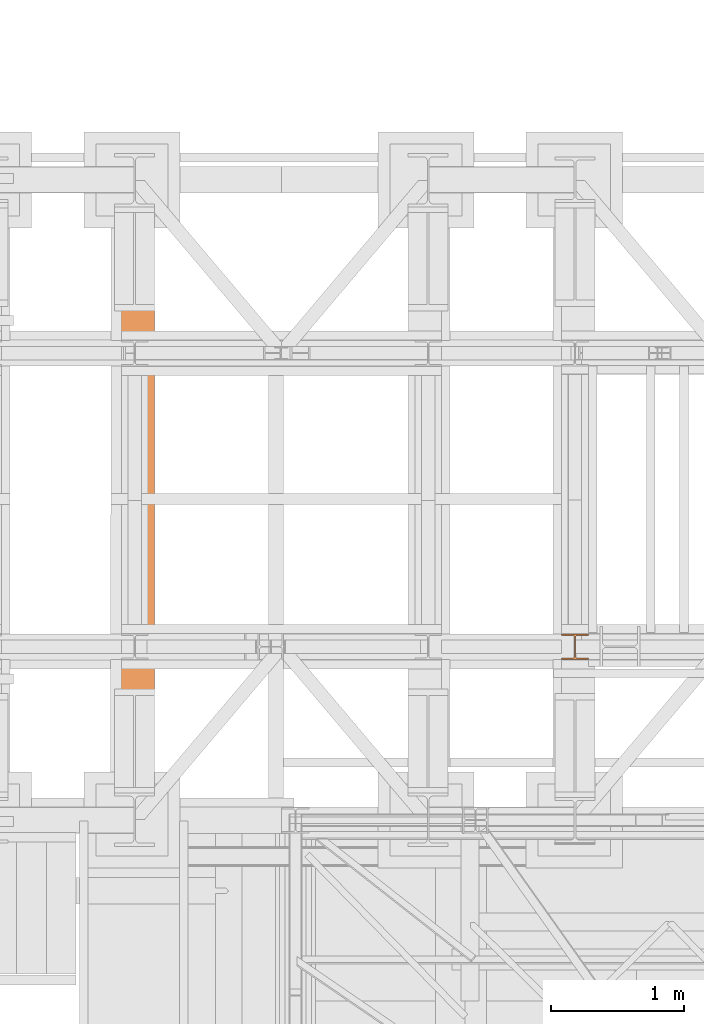
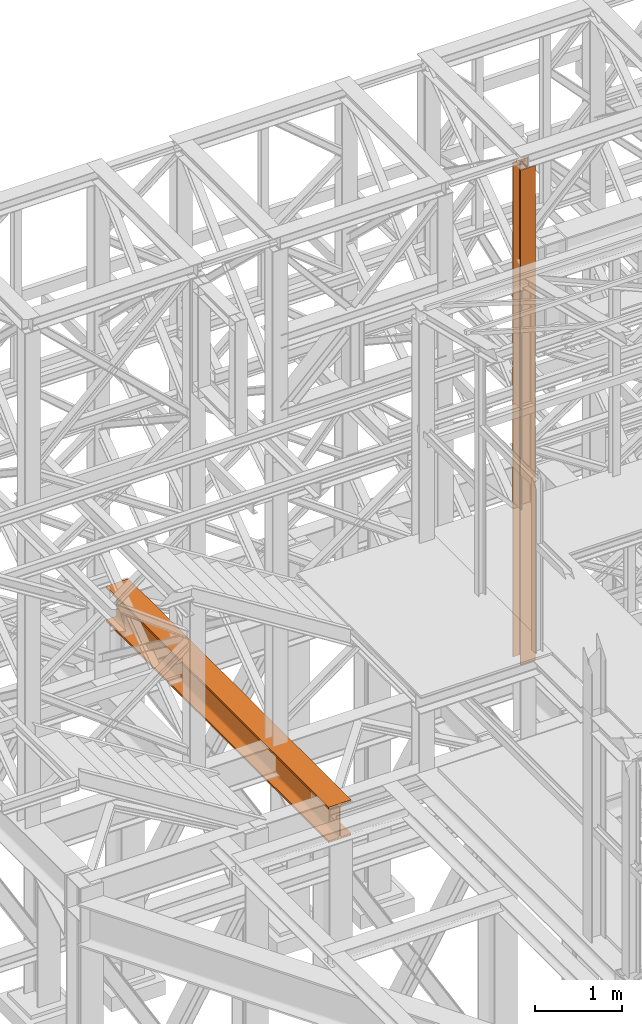
# One storey, part 114 of 208: 2 proxies.
"""IFC2X3 building model written with IfcOpenShell, lengths in millimetres."""

import ifcopenshell
import ifcopenshell.guid

model = None  # the IFC model being written
_history = None  # IfcOwnerHistory: only IFC2X3 demands one
_inside = {}  # id of a spatial element -> (the spatial element, [elements in it])
_under = {}  # id of a project, library or spatial element -> (it, [spatial elements below it])
_declared = {}  # id of a project -> (the project, [libraries it declares])
_typed = {}  # id of a type object -> (the type object, [elements of that type])
_made_of = {}  # id of a material, layer set ... -> (it, [elements and type objects made of it])


def new_model(schema):
    """Start an empty IFC model of exactly this schema.

    Asked for "IFC4X3", IfcOpenShell would pick the latest addendum, in which some entities
    have other attributes; the version numbers below select the first issue.
    IFC2X3 requires an IfcOwnerHistory on every rooted entity: one is made here for all.
    """
    global model, _history
    if schema == "IFC4X3":
        model = ifcopenshell.file(schema_version=(4, 3, 0, 0))
    else:
        model = ifcopenshell.file(schema=schema)
    _inside.clear()
    _under.clear()
    _declared.clear()
    _typed.clear()
    _made_of.clear()
    _history = None
    if model.schema == "IFC2X3":
        org = make("IfcOrganization", Name="unknown")
        user = make(
            "IfcPersonAndOrganization",
            ThePerson=make("IfcPerson", FamilyName="unknown"),
            TheOrganization=org,
        )
        app = make(
            "IfcApplication",
            ApplicationDeveloper=org,
            Version="unknown",
            ApplicationFullName="unknown",
            ApplicationIdentifier="unknown",
        )
        _history = make(
            "IfcOwnerHistory",
            OwningUser=user,
            OwningApplication=app,
            ChangeAction="ADDED",
            CreationDate=0,
        )
    return model


def make(cls, **values):
    """One entity of the class cls with the attributes given. An attribute that is None is left unset."""
    return model.create_entity(
        cls, **{name: value for name, value in values.items() if value is not None}
    )


def entity(cls, *values):
    """Any entity or typed value of the class cls, its attributes in the order of the schema. None: left unset."""
    e = model.create_entity(cls)
    for i, value in enumerate(values):
        if value is not None:
            e[i] = value
    return e


def rooted(cls, **values):
    """An entity with a GlobalId (a new one), such as an element, a storey or a relation."""
    return make(cls, GlobalId=ifcopenshell.guid.new(), OwnerHistory=_history, **values)


def si_unit(unit_type, name, prefix=None):
    """IfcSIUnit, for example si_unit("LENGTHUNIT", "METRE", prefix="MILLI")."""
    return make("IfcSIUnit", UnitType=unit_type, Prefix=prefix, Name=name)


def converted_unit(unit_type, name, factor, base, dimensions=None, offset=None):
    """IfcConversionBasedUnit, such as the inch: factor (a typed value) times the base unit."""
    return make(
        "IfcConversionBasedUnit"
        if offset is None
        else "IfcConversionBasedUnitWithOffset",
        ConversionOffset=offset,
        Dimensions=None
        if dimensions is None
        else entity("IfcDimensionalExponents", *dimensions),
        UnitType=unit_type,
        Name=name,
        ConversionFactor=make(
            "IfcMeasureWithUnit", ValueComponent=factor, UnitComponent=base
        ),
    )


def assignment(units):
    """IfcUnitAssignment: the units of a project."""
    return None if units is None else make("IfcUnitAssignment", Units=units)


def point(xyz):
    """IfcCartesianPoint."""
    return None if xyz is None else make("IfcCartesianPoint", Coordinates=xyz)


def direction(xyz):
    """IfcDirection."""
    return None if xyz is None else make("IfcDirection", DirectionRatios=xyz)


def frame(location, z_axis=None, x_axis=None):
    """IfcAxis2Placement3D, a coordinate frame: its origin and axes. An axis left out is left unset."""
    return make(
        "IfcAxis2Placement3D",
        Location=point(location),
        Axis=direction(z_axis),
        RefDirection=direction(x_axis),
    )


def origin():
    """The frame at (0, 0, 0) with its axes left unset."""
    return frame((0.0, 0.0, 0.0))


def origin_with_axes():
    """The frame at (0, 0, 0) with the z axis (0, 0, 1) and the x axis (1, 0, 0) written out."""
    return frame((0.0, 0.0, 0.0), z_axis=(0.0, 0.0, 1.0), x_axis=(1.0, 0.0, 0.0))


def place(relative_to, where):
    """IfcLocalPlacement: puts the frame where relative to a parent placement (None: the world)."""
    return make(
        "IfcLocalPlacement", PlacementRelTo=relative_to, RelativePlacement=where
    )


def context(
    kind, dimensions, precision=None, world=None, true_north=None, identifier=None
):
    """IfcGeometricRepresentationContext, for example the 3D "Model" context."""
    return make(
        "IfcGeometricRepresentationContext",
        ContextIdentifier=identifier,
        ContextType=kind,
        CoordinateSpaceDimension=dimensions,
        Precision=precision,
        WorldCoordinateSystem=world,
        TrueNorth=true_north,
    )


def subcontext(parent, identifier, kind, view, scale=None):
    """IfcGeometricRepresentationSubContext, for example "Body" below "Model"."""
    return make(
        "IfcGeometricRepresentationSubContext",
        ContextIdentifier=identifier,
        ContextType=kind,
        ParentContext=parent,
        TargetScale=scale,
        TargetView=view,
    )


def project(units=None, contexts=None):
    """IfcProject with its units and contexts."""
    return rooted(
        "IfcProject",
        Name="project",
        RepresentationContexts=contexts,
        UnitsInContext=assignment(units),
    )


def spatial(cls, under=None, at=None, **own):
    """A site, building, storey or space (cls), placed at a placement, below another one or the project."""
    s = rooted(cls, ObjectPlacement=at, **own)
    if under is not None:
        _under.setdefault(under.id(), (under, []))[1].append(s)
    return s


def faces_of(points, faces, orient=None, outer=None):
    """IfcFace entities. A face is a list of loops; a loop is a list of indices into points, from 0.

    orient and outer hold one flag for each loop. By default every Orientation is true, the
    first loop of a face is its IfcFaceOuterBound and the others are IfcFaceBound.
    """
    made = []
    for i, loops in enumerate(faces):
        bounds = []
        for j, loop in enumerate(loops):
            is_outer = j == 0 if outer is None else outer[i][j]
            bounds.append(
                make(
                    "IfcFaceOuterBound" if is_outer else "IfcFaceBound",
                    Bound=make("IfcPolyLoop", Polygon=[points[k] for k in loop]),
                    Orientation=True if orient is None else orient[i][j],
                )
            )
        made.append(make("IfcFace", Bounds=bounds))
    return made


def faceted_brep(points, faces, orient=None, outer=None, voids=None):
    """IfcFacetedBrep: a solid bounded by flat faces; with voids (closed shells), ...WithVoids."""
    shared = [point(p) for p in points]
    hull = make("IfcClosedShell", CfsFaces=faces_of(shared, faces, orient, outer))
    if voids is None:
        return make("IfcFacetedBrep", Outer=hull)
    return make(
        "IfcFacetedBrepWithVoids",
        Outer=hull,
        Voids=[
            make(cls, CfsFaces=faces_of(shared, fs, o, b)) for cls, fs, o, b in voids
        ],
    )


def shape(context_of_items, identifier, shape_type, items):
    """IfcShapeRepresentation: the items that make up one representation, for example the "Body"."""
    return make(
        "IfcShapeRepresentation",
        ContextOfItems=context_of_items,
        RepresentationIdentifier=identifier,
        RepresentationType=shape_type,
        Items=items,
    )


def made_of(thing, what):
    """Note that an element or type object is made of a material, layer set ...; save() writes the relation."""
    if what is not None:
        _made_of.setdefault(what.id(), (what, []))[1].append(thing)
    return thing


def element(
    cls,
    number,
    at=None,
    inside=None,
    cuts=None,
    type_object=None,
    material=None,
    context=None,
    identifier="Body",
    shape_type=None,
    held_by="IfcProductDefinitionShape",
    body=None,
    shapes=None,
    **own,
):
    """One element of the class cls, such as IfcWall. Its Tag is "e" and its number.

    at: its placement. inside: the storey or other place that contains it. cuts: it is an
    opening in that element (IfcRelVoidsElement). A single representation is given by context,
    identifier, shape_type and body (its items); several are given by shapes. held_by: the class
    of the entity that holds the representations. save() writes the other relations.
    """
    e = rooted(cls, Tag="e%d" % number, ObjectPlacement=at, **own)
    if body is not None:
        shapes = [shape(context, identifier, shape_type, body)]
    if shapes is not None:
        e.Representation = make(held_by, Representations=shapes)
    if inside is not None:
        _inside.setdefault(inside.id(), (inside, []))[1].append(e)
    if cuts is not None:
        rooted(
            "IfcRelVoidsElement", RelatingBuildingElement=cuts, RelatedOpeningElement=e
        )
    if type_object is not None:
        _typed.setdefault(type_object.id(), (type_object, []))[1].append(e)
    return made_of(e, material)


def aggregate(whole, parts):
    """IfcRelAggregates: a whole, such as a stair, and the parts it consists of."""
    return rooted("IfcRelAggregates", RelatingObject=whole, RelatedObjects=parts)


def save(model, path):
    """Write the relations noted so far, then the file.

    IfcRelAggregates (storeys below a building ...), IfcRelContainedInSpatialStructure (elements
    in a storey), IfcRelDefinesByType, IfcRelAssociatesMaterial and IfcRelDeclares: one each for
    every whole, place, type object, material and project.
    """
    for whole, parts in _under.values():
        aggregate(whole, parts)
    for where, things in _inside.values():
        rooted(
            "IfcRelContainedInSpatialStructure",
            RelatedElements=things,
            RelatingStructure=where,
        )
    for kind, things in _typed.values():
        rooted("IfcRelDefinesByType", RelatedObjects=things, RelatingType=kind)
    for what, things in _made_of.values():
        rooted("IfcRelAssociatesMaterial", RelatedObjects=things, RelatingMaterial=what)
    for by, libraries in _declared.values():
        rooted("IfcRelDeclares", RelatingContext=by, RelatedDefinitions=libraries)
    model.write(path)


model = new_model("IFC2X3")

# Units and contexts
model_context = context("Model", 3, precision=1e-05, world=origin())
plan_context = context("Plan", 3, precision=1e-05, world=origin())
body_context = subcontext(model_context, "Body", "Model", "MODEL_VIEW")
ifc_project = project(units=[si_unit("LENGTHUNIT", "METRE", prefix="MILLI"), converted_unit("PLANEANGLEUNIT", "DEGREE", entity("IfcPlaneAngleMeasure", 0.0174532925199433), si_unit("PLANEANGLEUNIT", "RADIAN"), dimensions=[0, 0, 0, 0, 0, 0, 0]), si_unit("AREAUNIT", "SQUARE_METRE"), si_unit("VOLUMEUNIT", "CUBIC_METRE")], contexts=[model_context, plan_context])

# Building, storey
building_placement = place(None, origin())
building = spatial("IfcBuilding", under=ifc_project, at=building_placement, CompositionType="COMPLEX")
storey_placement = place(building_placement, origin_with_axes())
storey = spatial("IfcBuildingStorey", under=building, at=storey_placement, Name="Geschoss", CompositionType="ELEMENT")

# Proxies
proxy_1_placement = place(storey_placement, frame((-156.745025510865, -17432.57439531566, 4784.990005364415), z_axis=(0.0, 0.0, 1.0), x_axis=(1.0, 0.0, 0.0)))
element("IfcBuildingElementProxy", 1, at=proxy_1_placement, inside=storey, context=body_context, shape_type="Brep", body=[
    faceted_brep([(300.01, 0.01000000000203727, 500.0100000000002), (300.0100000000006, 5140.010003576277, 500.0100000000002), (300.0100000000006, 5140.010003576277, 472.0100000000002), (300.01, 0.01000000000203727, 472.0100000000002), (300.01, 0.01000000000203727, 472.0100000000002), (300.0100000000006, 5140.010003576277, 472.0100000000002), (184.2600000000006, 5140.010003576277, 472.0100000000002), (184.26, 0.01000000000203727, 472.0100000000002), (184.26, 0.01000000000203727, 472.0100000000002), (184.2600000000006, 5140.010003576277, 472.0100000000002), (177.271909219226, 5140.010003576277, 471.0899181875066), (177.2719092192253, 0.01000000000203727, 471.0899181875066), (177.2719092192253, 0.01000000000203727, 471.0899181875066), (177.271909219226, 5140.010003576277, 471.0899181875066), (170.7600393754605, 5140.010003576277, 468.3926133818113), (170.7600393754599, 0.01000000000203727, 468.3926133818113), (170.7600393754599, 0.01000000000203727, 468.3926133818113), (170.7600393754605, 5140.010003576277, 468.3926133818113), (165.1681169079661, 5140.010003576277, 464.1018830920375), (165.1681169079654, 0.01000000000203727, 464.1018830920366), (165.1681169079654, 0.01000000000203727, 464.1018830920366), (165.1681169079661, 5140.010003576277, 464.1018830920375), (160.8773866181895, 5140.010003576277, 458.5099606245422), (160.8773866181889, 0.01000000000203727, 458.5099606245422), (160.8773866181889, 0.01000000000203727, 458.5099606245422), (160.8773866181895, 5140.010003576277, 458.5099606245422), (158.1800818124961, 5140.010003576277, 451.9980907807767), (158.1800818124955, 0.01000000000203727, 451.9980907807767), (158.1800818124955, 0.01000000000203727, 451.9980907807767), (158.1800818124961, 5140.010003576277, 451.9980907807767), (157.2600000000006, 5140.010003576277, 445.0100000000002), (157.26, 0.01000000000203727, 445.0100000000002), (157.26, 0.01000000000203727, 445.0100000000002), (157.2600000000006, 5140.010003576277, 445.0100000000002), (157.2600000000006, 5140.010003576277, 55.01000000000022), (157.26, 0.01000000000203727, 55.01000000000022), (157.26, 0.01000000000203727, 55.01000000000022), (157.2600000000006, 5140.010003576277, 55.01000000000022), (158.5815660577413, 5140.010003576277, 46.66656945413979), (158.5815660577407, 0.01000000000203727, 46.66656945413979), (158.5815660577407, 0.01000000000203727, 46.66656945413979), (158.5815660577413, 5140.010003576277, 46.66656945413979), (162.4165745365994, 5140.010003576277, 39.13982493419917), (162.4165745365988, 0.01000000000203727, 39.13982493419917), (162.4165745365988, 0.01000000000203727, 39.13982493419917), (162.4165745365994, 5140.010003576277, 39.13982493419917), (168.3898249342005, 5140.010003576277, 33.16657453659809), (168.3898249341999, 0.01000000000203727, 33.16657453659809), (168.3898249341999, 0.01000000000203727, 33.16657453659809), (168.3898249342005, 5140.010003576277, 33.16657453659809), (175.9165694541393, 5140.010003576277, 29.33156605774093), (175.9165694541387, 0.01000000000203727, 29.33156605774093), (175.9165694541387, 0.01000000000203727, 29.33156605774093), (175.9165694541393, 5140.010003576277, 29.33156605774093), (184.2600000000006, 5140.010003576277, 28.01000000000022), (184.26, 0.01000000000203727, 28.01000000000022), (184.26, 0.01000000000203727, 28.01000000000022), (184.2600000000006, 5140.010003576277, 28.01000000000022), (300.0100000000006, 5140.010003576277, 28.01000000000022), (300.01, 0.01000000000203727, 28.01000000000022), (300.01, 0.01000000000203727, 28.01000000000022), (300.0100000000006, 5140.010003576277, 28.01000000000022), (300.0100000000006, 5140.010003576277, 0.01000000000021828), (300.01, 0.01000000000203727, 0.01000000000021828), (300.01, 0.01000000000203727, 0.01000000000021828), (300.0100000000006, 5140.010003576277, 0.01000000000021828), (0.01000000000061618, 5140.010003576277, 0.01000000000021828), (0.009999999999990905, 0.01000000000203727, 0.01000000000021828), (0.009999999999990905, 0.01000000000203727, 0.01000000000021828), (0.01000000000061618, 5140.010003576277, 0.01000000000021828), (0.01000000000061618, 5140.010003576277, 28.01000000000022), (0.009999999999990905, 0.01000000000203727, 28.01000000000022), (0.009999999999990905, 0.01000000000203727, 28.01000000000022), (0.01000000000061618, 5140.010003576277, 28.01000000000022), (115.7600000000006, 5140.010003576277, 28.01000000000022), (115.76, 0.01000000000203727, 28.01000000000022), (115.76, 0.01000000000203727, 28.01000000000022), (115.7600000000006, 5140.010003576277, 28.01000000000022), (124.103430545862, 5140.010003576277, 29.33156605774093), (124.1034305458613, 0.01000000000203727, 29.33156605774093), (124.1034305458613, 0.01000000000203727, 29.33156605774093), (124.103430545862, 5140.010003576277, 29.33156605774093), (131.6301750658044, 5140.010003576277, 33.16657453659809), (131.6301750658038, 0.01000000000203727, 33.16657453659809), (131.6301750658038, 0.01000000000203727, 33.16657453659809), (131.6301750658044, 5140.010003576277, 33.16657453659809), (137.6034254634018, 5140.010003576277, 39.13982493419917), (137.6034254634012, 0.01000000000203727, 39.13982493419917), (137.6034254634012, 0.01000000000203727, 39.13982493419917), (137.6034254634018, 5140.010003576277, 39.13982493419917), (141.4384339422599, 5140.010003576277, 46.66656945413979), (141.4384339422593, 0.01000000000203727, 46.66656945413979), (141.4384339422593, 0.01000000000203727, 46.66656945413979), (141.4384339422599, 5140.010003576277, 46.66656945413979), (142.7600000000006, 5140.010003576277, 55.01000000000022), (142.76, 0.01000000000203727, 55.01000000000022), (142.76, 0.01000000000203727, 55.01000000000022), (142.7600000000006, 5140.010003576277, 55.01000000000022), (142.7600000000006, 5140.010003576277, 445.0100000000002), (142.76, 0.01000000000203727, 445.0100000000002), (142.76, 0.01000000000203727, 445.0100000000002), (142.7600000000006, 5140.010003576277, 445.0100000000002), (141.4384339422599, 5140.010003576277, 453.3534305458607), (141.4384339422593, 0.01000000000203727, 453.3534305458607), (141.4384339422593, 0.01000000000203727, 453.3534305458607), (141.4384339422599, 5140.010003576277, 453.3534305458607), (137.6034254634018, 5140.010003576277, 460.8801750658022), (137.6034254634012, 0.01000000000203727, 460.8801750658013), (137.6034254634012, 0.01000000000203727, 460.8801750658013), (137.6034254634018, 5140.010003576277, 460.8801750658022), (131.6301750658044, 5140.010003576277, 466.8534254634024), (131.6301750658038, 0.01000000000203727, 466.8534254634024), (131.6301750658038, 0.01000000000203727, 466.8534254634024), (131.6301750658044, 5140.010003576277, 466.8534254634024), (124.103430545862, 5140.010003576277, 470.6884339422595), (124.1034305458613, 0.01000000000203727, 470.6884339422595), (124.1034305458613, 0.01000000000203727, 470.6884339422595), (124.103430545862, 5140.010003576277, 470.6884339422595), (115.7600000000006, 5140.010003576277, 472.0100000000002), (115.76, 0.01000000000203727, 472.0100000000002), (115.76, 0.01000000000203727, 472.0100000000002), (115.7600000000006, 5140.010003576277, 472.0100000000002), (0.01000000000061618, 5140.010003576277, 472.0100000000002), (0.009999999999990905, 0.01000000000203727, 472.0100000000002), (0.009999999999990905, 0.01000000000203727, 472.0100000000002), (0.01000000000061618, 5140.010003576277, 472.0100000000002), (0.01000000000061618, 5140.010003576277, 500.0100000000002), (0.009999999999990905, 0.01000000000203727, 500.0100000000002), (0.009999999999990905, 0.01000000000203727, 500.0100000000002), (0.01000000000061618, 5140.010003576277, 500.0100000000002), (300.0100000000006, 5140.010003576277, 500.0100000000002), (300.01, 0.01000000000203727, 500.0100000000002), (300.01, 0.01000000000203727, 500.0100000000002), (300.01, 0.01000000000203727, 472.0100000000002), (184.26, 0.01000000000203727, 472.0100000000002), (177.2719092192253, 0.01000000000203727, 471.0899181875066), (170.7600393754599, 0.01000000000203727, 468.3926133818113), (165.1681169079654, 0.01000000000203727, 464.1018830920366), (160.8773866181889, 0.01000000000203727, 458.5099606245422), (158.1800818124955, 0.01000000000203727, 451.9980907807767), (157.26, 0.01000000000203727, 445.0100000000002), (157.26, 0.01000000000203727, 55.01000000000022), (158.5815660577407, 0.01000000000203727, 46.66656945413979), (162.4165745365988, 0.01000000000203727, 39.13982493419917), (168.3898249341999, 0.01000000000203727, 33.16657453659809), (175.9165694541387, 0.01000000000203727, 29.33156605774093), (184.26, 0.01000000000203727, 28.01000000000022), (300.01, 0.01000000000203727, 28.01000000000022), (300.01, 0.01000000000203727, 0.01000000000021828), (0.009999999999990905, 0.01000000000203727, 0.01000000000021828), (0.009999999999990905, 0.01000000000203727, 28.01000000000022), (115.76, 0.01000000000203727, 28.01000000000022), (124.1034305458613, 0.01000000000203727, 29.33156605774093), (131.6301750658038, 0.01000000000203727, 33.16657453659809), (137.6034254634012, 0.01000000000203727, 39.13982493419917), (141.4384339422593, 0.01000000000203727, 46.66656945413979), (142.76, 0.01000000000203727, 55.01000000000022), (142.76, 0.01000000000203727, 445.0100000000002), (141.4384339422593, 0.01000000000203727, 453.3534305458607), (137.6034254634012, 0.01000000000203727, 460.8801750658013), (131.6301750658038, 0.01000000000203727, 466.8534254634024), (124.1034305458613, 0.01000000000203727, 470.6884339422595), (115.76, 0.01000000000203727, 472.0100000000002), (0.009999999999990905, 0.01000000000203727, 472.0100000000002), (0.009999999999990905, 0.01000000000203727, 500.0100000000002), (300.0100000000006, 5140.010003576277, 500.0100000000002), (0.01000000000061618, 5140.010003576277, 500.0100000000002), (0.01000000000061618, 5140.010003576277, 472.0100000000002), (115.7600000000006, 5140.010003576277, 472.0100000000002), (124.103430545862, 5140.010003576277, 470.6884339422595), (131.6301750658044, 5140.010003576277, 466.8534254634024), (137.6034254634018, 5140.010003576277, 460.8801750658022), (141.4384339422599, 5140.010003576277, 453.3534305458607), (142.7600000000006, 5140.010003576277, 445.0100000000002), (142.7600000000006, 5140.010003576277, 55.01000000000022), (141.4384339422599, 5140.010003576277, 46.66656945413979), (137.6034254634018, 5140.010003576277, 39.13982493419917), (131.6301750658044, 5140.010003576277, 33.16657453659809), (124.103430545862, 5140.010003576277, 29.33156605774093), (115.7600000000006, 5140.010003576277, 28.01000000000022), (0.01000000000061618, 5140.010003576277, 28.01000000000022), (0.01000000000061618, 5140.010003576277, 0.01000000000021828), (300.0100000000006, 5140.010003576277, 0.01000000000021828), (300.0100000000006, 5140.010003576277, 28.01000000000022), (184.2600000000006, 5140.010003576277, 28.01000000000022), (175.9165694541393, 5140.010003576277, 29.33156605774093), (168.3898249342005, 5140.010003576277, 33.16657453659809), (162.4165745365994, 5140.010003576277, 39.13982493419917), (158.5815660577413, 5140.010003576277, 46.66656945413979), (157.2600000000006, 5140.010003576277, 55.01000000000022), (157.2600000000006, 5140.010003576277, 445.0100000000002), (158.1800818124961, 5140.010003576277, 451.9980907807767), (160.8773866181895, 5140.010003576277, 458.5099606245422), (165.1681169079661, 5140.010003576277, 464.1018830920375), (170.7600393754605, 5140.010003576277, 468.3926133818113), (177.271909219226, 5140.010003576277, 471.0899181875066), (184.2600000000006, 5140.010003576277, 472.0100000000002), (300.0100000000006, 5140.010003576277, 472.0100000000002)], [[[0, 1, 2, 3]], [[4, 5, 6, 7]], [[8, 9, 10, 11]], [[12, 13, 14, 15]], [[16, 17, 18, 19]], [[20, 21, 22, 23]], [[24, 25, 26, 27]], [[28, 29, 30, 31]], [[32, 33, 34, 35]], [[36, 37, 38, 39]], [[40, 41, 42, 43]], [[44, 45, 46, 47]], [[48, 49, 50, 51]], [[52, 53, 54, 55]], [[56, 57, 58, 59]], [[60, 61, 62, 63]], [[64, 65, 66, 67]], [[68, 69, 70, 71]], [[72, 73, 74, 75]], [[76, 77, 78, 79]], [[80, 81, 82, 83]], [[84, 85, 86, 87]], [[88, 89, 90, 91]], [[92, 93, 94, 95]], [[96, 97, 98, 99]], [[100, 101, 102, 103]], [[104, 105, 106, 107]], [[108, 109, 110, 111]], [[112, 113, 114, 115]], [[116, 117, 118, 119]], [[120, 121, 122, 123]], [[124, 125, 126, 127]], [[128, 129, 130, 131]], [[132, 133, 134, 135, 136, 137, 138, 139, 140, 141, 142, 143, 144, 145, 146, 147, 148, 149, 150, 151, 152, 153, 154, 155, 156, 157, 158, 159, 160, 161, 162, 163, 164]], [[165, 166, 167, 168, 169, 170, 171, 172, 173, 174, 175, 176, 177, 178, 179, 180, 181, 182, 183, 184, 185, 186, 187, 188, 189, 190, 191, 192, 193, 194, 195, 196, 197]]], orient=[[False], [False], [False], [False], [False], [False], [False], [False], [False], [False], [False], [False], [False], [False], [False], [False], [False], [False], [False], [False], [False], [False], [False], [False], [False], [False], [False], [False], [False], [False], [False], [False], [False], [False], [False]]),
])
proxy_2_placement = place(storey_placement, frame((3193.25496703855, -16057.57439657638, 5284.990005364419), z_axis=(0.0, 0.0, 1.0), x_axis=(1.0, 0.0, 0.0)))
element("IfcBuildingElementProxy", 2, at=proxy_2_placement, inside=storey, context=body_context, shape_type="Brep", body=[
    faceted_brep([(0.01000000000021828, 190.0100125169774, 6965.010053329391), (200.0100029802325, 190.0100125169774, 6965.010053329391), (200.0100029802325, 180.01001460314, 6965.010053329391), (121.2600035762789, 180.0100071525594, 6965.010053329391), (111.9441915473344, 178.1454621052762, 6965.010053329391), (105.1245498640838, 171.3258190250417, 6965.010053329391), (103.2600015571716, 162.0100079274198, 6965.010053329391), (103.2600015571716, 28.00999713897909, 6965.010053329391), (105.1245498640838, 18.69418604135717, 6965.010053329391), (111.9441915473344, 11.87454296112264, 6965.010053329391), (121.2600035762789, 10.00999791383947, 6965.010053329391), (200.0100029802325, 10.00999791383947, 6965.010053329391), (200.0100029802325, 0.01000000000203727, 6965.010053329391), (0.01000000000021828, 0.01000000000203727, 6965.010053329391), (0.01000000000021828, 10.00999791383947, 6965.010053329391), (78.75999940395377, 10.00999791383947, 6965.010053329391), (88.07581143289826, 11.87454296112264, 6965.010053329391), (94.89545311614893, 18.69418604135717, 6965.010053329391), (96.76000142306111, 28.00999713897909, 6965.010053329391), (96.76000142306111, 162.0100079274198, 6965.010053329391), (94.89545311614893, 171.3258190250417, 6965.010053329391), (88.07581143289826, 178.1454621052762, 6965.010053329391), (78.75999940395377, 180.0100071525594, 6965.010053329391), (0.01000000000021828, 180.01001460314, 6965.010053329391), (200.0100029802325, 190.0100125169774, 6965.010053329391), (0.01000000000021828, 190.0100125169774, 6965.010053329391), (0.01000000000067303, 190.0100125169756, 0.009999999999308784), (200.0100029802329, 190.0100125169756, 0.009999999999308784), (200.0100029802325, 180.01001460314, 6965.010053329391), (200.0100029802325, 190.0100125169774, 6965.010053329391), (200.0100029802329, 190.0100125169756, 0.009999999999308784), (200.0100029802329, 180.0100146031382, 0.009999999999308784), (121.2600035762789, 180.0100071525594, 6965.010053329391), (200.0100029802325, 180.01001460314, 6965.010053329391), (200.0100029802329, 180.0100146031382, 0.009999999999308784), (121.2600035762794, 180.0100071525576, 0.009999999999308784), (111.9441915473344, 178.1454621052762, 6965.010053329391), (121.2600035762789, 180.0100071525594, 6965.010053329391), (121.2600035762794, 180.0100071525576, 0.009999999999308784), (111.9441915473349, 178.1454621052744, 0.009999999999308784), (105.1245498640838, 171.3258190250417, 6965.010053329391), (111.9441915473344, 178.1454621052762, 6965.010053329391), (111.9441915473349, 178.1454621052744, 0.009999999999308784), (105.1245498640842, 171.3258190250399, 0.009999999999308784), (103.2600015571716, 162.0100079274198, 6965.010053329391), (105.1245498640838, 171.3258190250417, 6965.010053329391), (105.1245498640842, 171.3258190250399, 0.009999999999308784), (103.260001557172, 162.010007927418, 0.009999999999308784), (103.2600015571716, 28.00999713897909, 6965.010053329391), (103.2600015571716, 162.0100079274198, 6965.010053329391), (103.260001557172, 162.010007927418, 0.009999999999308784), (103.260001557172, 28.00999713897727, 0.009999999999308784), (105.1245498640838, 18.69418604135717, 6965.010053329391), (103.2600015571716, 28.00999713897909, 6965.010053329391), (103.260001557172, 28.00999713897727, 0.009999999999308784), (105.1245498640842, 18.69418604135535, 0.009999999999308784), (111.9441915473344, 11.87454296112264, 6965.010053329391), (105.1245498640838, 18.69418604135717, 6965.010053329391), (105.1245498640842, 18.69418604135535, 0.009999999999308784), (111.9441915473349, 11.87454296112082, 0.009999999999308784), (121.2600035762789, 10.00999791383947, 6965.010053329391), (111.9441915473344, 11.87454296112264, 6965.010053329391), (111.9441915473349, 11.87454296112082, 0.009999999999308784), (121.2600035762794, 10.00999791383765, 0.009999999999308784), (200.0100029802325, 10.00999791383947, 6965.010053329391), (121.2600035762789, 10.00999791383947, 6965.010053329391), (121.2600035762794, 10.00999791383765, 0.009999999999308784), (200.0100029802329, 10.00999791383765, 0.009999999999308784), (200.0100029802325, 0.01000000000203727, 6965.010053329391), (200.0100029802325, 10.00999791383947, 6965.010053329391), (200.0100029802329, 10.00999791383765, 0.009999999999308784), (200.0100029802329, 0.01000000000021828, 0.009999999999308784), (0.01000000000021828, 0.01000000000203727, 6965.010053329391), (200.0100029802325, 0.01000000000203727, 6965.010053329391), (200.0100029802329, 0.01000000000021828, 0.009999999999308784), (0.01000000000067303, 0.01000000000021828, 0.009999999999308784), (0.01000000000021828, 10.00999791383947, 6965.010053329391), (0.01000000000021828, 0.01000000000203727, 6965.010053329391), (0.01000000000067303, 0.01000000000021828, 0.009999999999308784), (0.01000000000067303, 10.00999791383765, 0.009999999999308784), (78.75999940395377, 10.00999791383947, 6965.010053329391), (0.01000000000021828, 10.00999791383947, 6965.010053329391), (0.01000000000067303, 10.00999791383765, 0.009999999999308784), (78.75999940395423, 10.00999791383765, 0.009999999999308784), (88.07581143289826, 11.87454296112264, 6965.010053329391), (78.75999940395377, 10.00999791383947, 6965.010053329391), (78.75999940395423, 10.00999791383765, 0.009999999999308784), (88.07581143289872, 11.87454296112082, 0.009999999999308784), (94.89545311614893, 18.69418604135717, 6965.010053329391), (88.07581143289826, 11.87454296112264, 6965.010053329391), (88.07581143289872, 11.87454296112082, 0.009999999999308784), (94.89545311614938, 18.69418604135535, 0.009999999999308784), (96.76000142306111, 28.00999713897909, 6965.010053329391), (94.89545311614893, 18.69418604135717, 6965.010053329391), (94.89545311614938, 18.69418604135535, 0.009999999999308784), (96.76000142306157, 28.00999713897727, 0.009999999999308784), (96.76000142306111, 162.0100079274198, 6965.010053329391), (96.76000142306111, 28.00999713897909, 6965.010053329391), (96.76000142306157, 28.00999713897727, 0.009999999999308784), (96.76000142306157, 162.010007927418, 0.009999999999308784), (94.89545311614893, 171.3258190250417, 6965.010053329391), (96.76000142306111, 162.0100079274198, 6965.010053329391), (96.76000142306157, 162.010007927418, 0.009999999999308784), (94.89545311614938, 171.3258190250399, 0.009999999999308784), (88.07581143289826, 178.1454621052762, 6965.010053329391), (94.89545311614893, 171.3258190250417, 6965.010053329391), (94.89545311614938, 171.3258190250399, 0.009999999999308784), (88.07581143289872, 178.1454621052744, 0.009999999999308784), (78.75999940395377, 180.0100071525594, 6965.010053329391), (88.07581143289826, 178.1454621052762, 6965.010053329391), (88.07581143289872, 178.1454621052744, 0.009999999999308784), (78.75999940395423, 180.0100071525576, 0.009999999999308784), (0.01000000000021828, 180.01001460314, 6965.010053329391), (78.75999940395377, 180.0100071525594, 6965.010053329391), (78.75999940395423, 180.0100071525576, 0.009999999999308784), (0.01000000000067303, 180.0100146031382, 0.009999999999308784), (0.01000000000021828, 190.0100125169774, 6965.010053329391), (0.01000000000021828, 180.01001460314, 6965.010053329391), (0.01000000000067303, 180.0100146031382, 0.009999999999308784), (0.01000000000067303, 190.0100125169756, 0.009999999999308784), (0.01000000000067303, 190.0100125169756, 0.009999999999308784), (0.01000000000067303, 180.0100146031382, 0.009999999999308784), (78.75999940395423, 180.0100071525576, 0.009999999999308784), (88.07581143289872, 178.1454621052744, 0.009999999999308784), (94.89545311614938, 171.3258190250399, 0.009999999999308784), (96.76000142306157, 162.010007927418, 0.009999999999308784), (96.76000142306157, 28.00999713897727, 0.009999999999308784), (94.89545311614938, 18.69418604135535, 0.009999999999308784), (88.07581143289872, 11.87454296112082, 0.009999999999308784), (78.75999940395423, 10.00999791383765, 0.009999999999308784), (0.01000000000067303, 10.00999791383765, 0.009999999999308784), (0.01000000000067303, 0.01000000000021828, 0.009999999999308784), (200.0100029802329, 0.01000000000021828, 0.009999999999308784), (200.0100029802329, 10.00999791383765, 0.009999999999308784), (121.2600035762794, 10.00999791383765, 0.009999999999308784), (111.9441915473349, 11.87454296112082, 0.009999999999308784), (105.1245498640842, 18.69418604135535, 0.009999999999308784), (103.260001557172, 28.00999713897727, 0.009999999999308784), (103.260001557172, 162.010007927418, 0.009999999999308784), (105.1245498640842, 171.3258190250399, 0.009999999999308784), (111.9441915473349, 178.1454621052744, 0.009999999999308784), (121.2600035762794, 180.0100071525576, 0.009999999999308784), (200.0100029802329, 180.0100146031382, 0.009999999999308784), (200.0100029802329, 190.0100125169756, 0.009999999999308784)], [[[0, 1, 2, 3, 4, 5, 6, 7, 8, 9, 10, 11, 12, 13, 14, 15, 16, 17, 18, 19, 20, 21, 22, 23]], [[24, 25, 26, 27]], [[28, 29, 30, 31]], [[32, 33, 34, 35]], [[36, 37, 38, 39]], [[40, 41, 42, 43]], [[44, 45, 46, 47]], [[48, 49, 50, 51]], [[52, 53, 54, 55]], [[56, 57, 58, 59]], [[60, 61, 62, 63]], [[64, 65, 66, 67]], [[68, 69, 70, 71]], [[72, 73, 74, 75]], [[76, 77, 78, 79]], [[80, 81, 82, 83]], [[84, 85, 86, 87]], [[88, 89, 90, 91]], [[92, 93, 94, 95]], [[96, 97, 98, 99]], [[100, 101, 102, 103]], [[104, 105, 106, 107]], [[108, 109, 110, 111]], [[112, 113, 114, 115]], [[116, 117, 118, 119]], [[120, 121, 122, 123, 124, 125, 126, 127, 128, 129, 130, 131, 132, 133, 134, 135, 136, 137, 138, 139, 140, 141, 142, 143]]], orient=[[False], [False], [False], [False], [False], [False], [False], [False], [False], [False], [False], [False], [False], [False], [False], [False], [False], [False], [False], [False], [False], [False], [False], [False], [False], [False]]),
])

save(model, "model.ifc")
